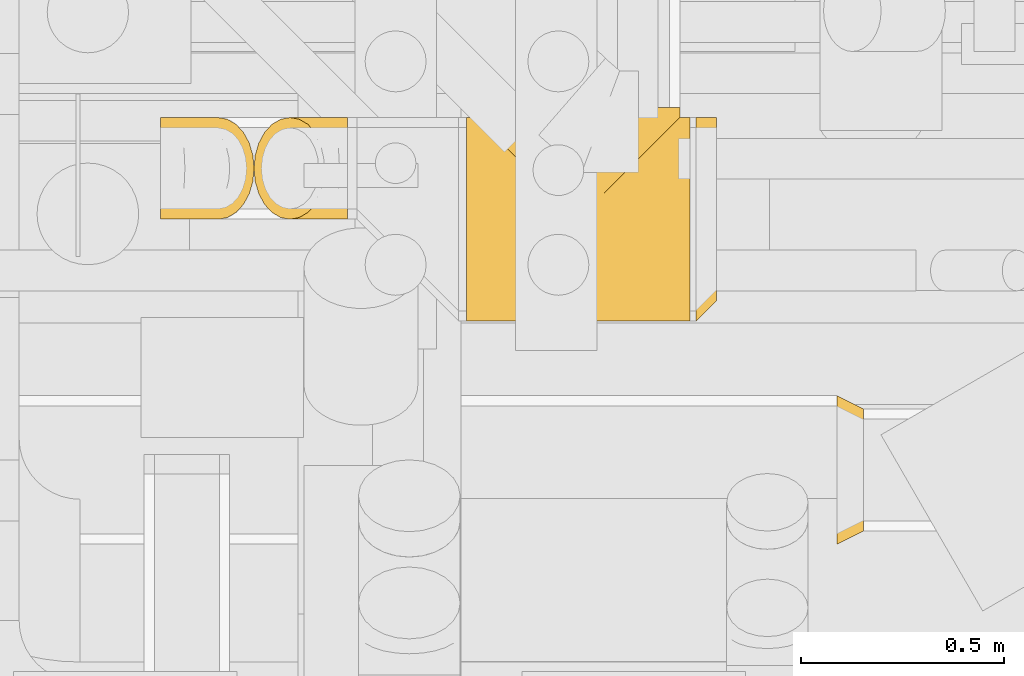
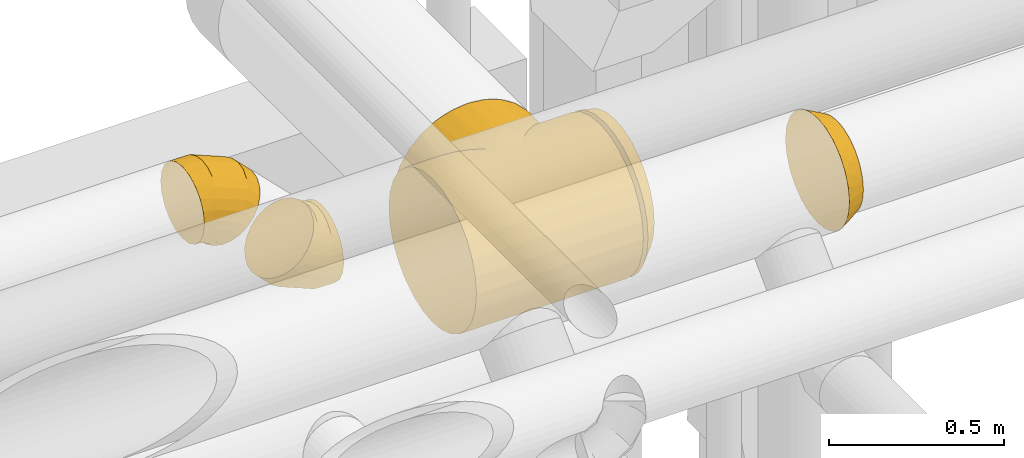
# One storey, part 15 of 337: 5 coverings.
"""IFC2X3 building model written with IfcOpenShell, lengths in millimetres."""

from ifc_helpers import new_model, entity, si_unit, converted_unit, derived_unit, direction, frame, origin, place, context, subcontext, project, spatial, faceted_brep, element, save


model = new_model("IFC2X3")

# Units and contexts
model_context = context("Model", 3, precision=0.01, world=origin(), true_north=direction((6.12303176911189e-17, 1.0)))
body_context = subcontext(model_context, "Body", "Model", "MODEL_VIEW")
ifc_project = project(units=[si_unit("LENGTHUNIT", "METRE", prefix="MILLI"), si_unit("AREAUNIT", "SQUARE_METRE"), si_unit("VOLUMEUNIT", "CUBIC_METRE"), converted_unit("PLANEANGLEUNIT", "DEGREE", entity("IfcRatioMeasure", 0.0174532925199433), si_unit("PLANEANGLEUNIT", "RADIAN"), dimensions=[0, 0, 0, 0, 0, 0, 0]), si_unit("MASSUNIT", "GRAM", prefix="KILO"), derived_unit("MASSDENSITYUNIT", [(si_unit("MASSUNIT", "GRAM", prefix="KILO"), 1), (si_unit("LENGTHUNIT", "METRE"), -3)]), derived_unit("MOMENTOFINERTIAUNIT", [(si_unit("LENGTHUNIT", "METRE"), 4)]), si_unit("TIMEUNIT", "SECOND"), si_unit("FREQUENCYUNIT", "HERTZ"), si_unit("THERMODYNAMICTEMPERATUREUNIT", "DEGREE_CELSIUS"), derived_unit("THERMALTRANSMITTANCEUNIT", [(si_unit("MASSUNIT", "GRAM", prefix="KILO"), 1), (si_unit("THERMODYNAMICTEMPERATUREUNIT", "KELVIN"), -1), (si_unit("TIMEUNIT", "SECOND"), -3)]), derived_unit("VOLUMETRICFLOWRATEUNIT", [(si_unit("LENGTHUNIT", "METRE"), 3), (si_unit("TIMEUNIT", "SECOND"), -1)]), derived_unit("MASSFLOWRATEUNIT", [(si_unit("MASSUNIT", "GRAM", prefix="KILO"), 1), (si_unit("TIMEUNIT", "SECOND"), -1)]), derived_unit("ROTATIONALFREQUENCYUNIT", [(si_unit("TIMEUNIT", "SECOND"), -1)]), si_unit("ELECTRICCURRENTUNIT", "AMPERE"), si_unit("ELECTRICVOLTAGEUNIT", "VOLT"), si_unit("POWERUNIT", "WATT"), si_unit("FORCEUNIT", "NEWTON", prefix="KILO"), si_unit("ILLUMINANCEUNIT", "LUX"), si_unit("LUMINOUSFLUXUNIT", "LUMEN"), si_unit("LUMINOUSINTENSITYUNIT", "CANDELA"), derived_unit("USERDEFINED", [(si_unit("MASSUNIT", "GRAM", prefix="KILO"), -1), (si_unit("LENGTHUNIT", "METRE"), -2), (si_unit("TIMEUNIT", "SECOND"), 3), (si_unit("LUMINOUSFLUXUNIT", "LUMEN"), 1)]), derived_unit("LINEARVELOCITYUNIT", [(si_unit("LENGTHUNIT", "METRE"), 1), (si_unit("TIMEUNIT", "SECOND"), -1)]), si_unit("PRESSUREUNIT", "PASCAL"), derived_unit("USERDEFINED", [(si_unit("LENGTHUNIT", "METRE"), -2), (si_unit("MASSUNIT", "GRAM", prefix="KILO"), 1), (si_unit("TIMEUNIT", "SECOND"), -2)]), derived_unit("LINEARFORCEUNIT", [(si_unit("MASSUNIT", "GRAM", prefix="KILO"), 1), (si_unit("LENGTHUNIT", "METRE"), 1), (si_unit("TIMEUNIT", "SECOND"), -2), (si_unit("LENGTHUNIT", "METRE"), -1)]), derived_unit("PLANARFORCEUNIT", [(si_unit("MASSUNIT", "GRAM", prefix="KILO"), 1), (si_unit("LENGTHUNIT", "METRE"), 1), (si_unit("TIMEUNIT", "SECOND"), -2), (si_unit("LENGTHUNIT", "METRE"), -2)])], contexts=[model_context])

# Site, building, storey
site_placement = place(None, origin())
site = spatial("IfcSite", under=ifc_project, at=site_placement, CompositionType="ELEMENT")
building_placement = place(site_placement, origin())
building = spatial("IfcBuilding", under=site, at=building_placement, CompositionType="ELEMENT")
storey_placement = place(building_placement, origin())
storey = spatial("IfcBuildingStorey", under=building, at=storey_placement, CompositionType="ELEMENT", Elevation=0.0)

# Coverings
covering_1_placement = place(storey_placement, frame((57310.12, 9473.4, 2914.23)))
element("IfcCovering", 1, at=covering_1_placement, inside=storey, PredefinedType="INSULATION", context=body_context, shape_type="Brep", body=[
    faceted_brep([(550.0, 500.03, 237.69), (524.43, 501.03, 239.69), (550.0, 501.6, 251.6), (550.0, 496.89, 209.87), (550.0, 495.33, 195.97), (520.5, 497.1, 204.39), (523.86, 500.46, 227.78), (550.0, 498.46, 223.78), (550.0, 486.08, 169.54), (550.0, 476.84, 143.12), (507.73, 484.33, 160.3), (517.78, 494.38, 193.1), (522.18, 498.78, 216.09), (550.0, 447.05, 95.72), (476.75, 453.34, 103.95), (550.0, 461.95, 119.42), (515.06, 491.65, 181.8), (550.0, 490.7, 182.75), (308.7, 285.3, 3.88), (413.02, 251.6, 1.6), (291.87, 268.47, 2.17), (498.75, 475.35, 140.08), (525.0, 501.6, 251.6), (25.57, 501.03, 239.69), (0.0, 501.6, 251.6), (25.0, 501.6, 251.6), (488.35, 464.95, 121.28), (450.66, 427.25, 73.71), (464.13, 440.72, 88.1), (550.0, 407.47, 56.14), (436.48, 413.08, 60.75), (421.72, 398.31, 49.18), (550.0, 360.07, 26.35), (374.82, 351.42, 22.39), (550.0, 307.23, 7.86), (390.81, 367.41, 30.04), (406.47, 383.06, 38.95), (550.0, 251.6, 1.6), (0.0, 251.6, 1.6), (0.0, 307.23, 7.86), (136.98, 251.6, 1.6), (342.09, 318.69, 10.77), (358.56, 335.16, 15.97), (325.46, 302.05, 6.74), (275.0, 251.6, 1.6), (258.13, 268.47, 2.17), (307.1, 283.7, 499.53), (550.0, 251.6, 501.6), (550.0, 307.23, 495.33), (400.54, 377.14, 467.79), (550.0, 360.07, 476.84), (550.0, 407.47, 447.05), (429.52, 406.11, 448.13), (443.31, 419.91, 436.45), (370.2, 346.8, 482.76), (515.09, 491.69, 317.74), (550.0, 486.08, 333.65), (550.0, 490.7, 320.44), (550.0, 495.33, 307.23), (275.0, 251.6, 501.6), (242.9, 283.7, 499.53), (0.0, 251.6, 501.6), (520.92, 497.51, 296.6), (518.0, 494.6, 307.17), (338.94, 315.53, 493.28), (523.98, 500.57, 262.85), (26.02, 500.57, 262.85), (550.0, 498.46, 279.41), (522.96, 499.55, 274.1), (521.94, 498.53, 285.35), (550.0, 496.89, 293.32), (550.0, 500.03, 265.5), (491.46, 468.05, 376.68), (550.0, 461.95, 383.77), (550.0, 476.84, 360.07), (469.04, 445.64, 409.23), (550.0, 447.05, 407.47), (500.36, 476.96, 357.79), (509.26, 485.86, 338.89), (0.0, 7.86, 195.97), (0.0, 1.6, 251.6), (0.0, 7.86, 307.23), (0.0, 26.35, 360.07), (0.0, 56.14, 407.47), (0.0, 95.72, 447.05), (0.0, 143.12, 476.84), (0.0, 195.97, 495.33), (0.0, 307.23, 495.33), (0.0, 360.07, 476.84), (0.0, 407.47, 447.05), (0.0, 447.05, 407.47), (0.0, 461.95, 383.77), (0.0, 476.84, 360.07), (0.0, 486.08, 333.65), (0.0, 490.7, 320.44), (0.0, 495.33, 307.23), (0.0, 496.89, 293.32), (0.0, 498.46, 279.41), (0.0, 500.03, 265.5), (0.0, 500.03, 237.69), (0.0, 498.46, 223.78), (0.0, 496.89, 209.87), (0.0, 495.33, 195.97), (0.0, 490.7, 182.75), (0.0, 486.08, 169.54), (0.0, 476.84, 143.12), (0.0, 461.95, 119.42), (0.0, 447.05, 95.72), (0.0, 407.47, 56.14), (0.0, 360.07, 26.35), (0.0, 195.97, 7.86), (0.0, 143.12, 26.35), (0.0, 95.72, 56.14), (0.0, 56.14, 95.72), (0.0, 26.35, 143.12), (550.0, 195.97, 495.33), (550.0, 143.12, 476.84), (550.0, 95.72, 447.05), (550.0, 56.14, 407.47), (550.0, 26.35, 360.07), (550.0, 7.86, 307.23), (550.0, 1.6, 251.6), (550.0, 7.86, 195.97), (550.0, 26.35, 143.12), (550.0, 56.14, 95.72), (550.0, 95.72, 56.14), (550.0, 143.12, 26.35), (550.0, 195.97, 7.86), (28.06, 498.53, 285.35), (27.04, 499.55, 274.1), (29.08, 497.51, 296.6), (34.91, 491.69, 317.74), (32.0, 494.6, 307.17), (179.8, 346.8, 482.76), (149.46, 377.14, 467.79), (211.06, 315.53, 493.28), (120.48, 406.11, 448.13), (106.69, 419.91, 436.45), (80.96, 445.64, 409.23), (58.54, 468.05, 376.68), (40.74, 485.86, 338.89), (49.64, 476.96, 357.79), (29.5, 497.1, 204.39), (32.22, 494.38, 193.1), (42.27, 484.33, 160.3), (51.25, 475.35, 140.08), (85.87, 440.72, 88.1), (99.34, 427.25, 73.71), (34.94, 491.65, 181.8), (73.25, 453.34, 103.95), (26.14, 500.46, 227.78), (27.82, 498.78, 216.09), (61.65, 464.95, 121.28), (191.44, 335.16, 15.97), (207.91, 318.69, 10.77), (175.18, 351.42, 22.39), (241.3, 285.3, 3.88), (224.54, 302.05, 6.74), (128.28, 398.31, 49.18), (113.52, 413.08, 60.75), (143.53, 383.06, 38.95), (159.19, 367.41, 30.04), (330.63, 526.6, 495.33), (383.47, 526.6, 476.84), (430.87, 526.6, 447.05), (470.46, 526.6, 407.47), (485.35, 526.6, 383.77), (500.24, 526.6, 360.07), (509.49, 526.6, 333.65), (514.11, 526.6, 320.44), (518.73, 526.6, 307.23), (520.3, 526.6, 293.32), (521.87, 526.6, 279.41), (523.43, 526.6, 265.5), (525.0, 526.6, 251.6), (523.43, 526.6, 237.69), (521.87, 526.6, 223.78), (520.3, 526.6, 209.87), (518.73, 526.6, 195.97), (514.11, 526.6, 182.75), (509.49, 526.6, 169.54), (500.24, 526.6, 143.12), (485.35, 526.6, 119.42), (470.46, 526.6, 95.72), (430.87, 526.6, 56.14), (383.47, 526.6, 26.35), (330.63, 526.6, 7.86), (275.0, 526.6, 1.6), (219.37, 526.6, 7.86), (166.53, 526.6, 26.35), (119.13, 526.6, 56.14), (79.54, 526.6, 95.72), (64.65, 526.6, 119.42), (49.76, 526.6, 143.12), (40.51, 526.6, 169.54), (35.89, 526.6, 182.75), (31.27, 526.6, 195.97), (29.7, 526.6, 209.87), (28.13, 526.6, 223.78), (26.57, 526.6, 237.69), (25.0, 526.6, 251.6), (26.57, 526.6, 265.5), (28.13, 526.6, 279.41), (29.7, 526.6, 293.32), (31.27, 526.6, 307.23), (35.89, 526.6, 320.44), (40.51, 526.6, 333.65), (49.76, 526.6, 360.07), (64.65, 526.6, 383.77), (79.54, 526.6, 407.47), (119.13, 526.6, 447.05), (166.53, 526.6, 476.84), (219.37, 526.6, 495.33), (275.0, 526.6, 501.6), (275.0, 389.62, 1.6)], [[[0, 1, 2]], [[3, 4, 5]], [[6, 0, 7]], [[8, 9, 10]], [[11, 5, 4]], [[7, 3, 12]], [[13, 14, 15]], [[16, 17, 8]], [[18, 19, 20]], [[16, 8, 10]], [[21, 10, 9]], [[17, 11, 4]], [[2, 1, 22]], [[23, 24, 25]], [[26, 15, 14]], [[11, 17, 16]], [[27, 28, 13]], [[14, 13, 28]], [[7, 12, 6]], [[9, 15, 21]], [[21, 15, 26]], [[13, 29, 27]], [[3, 5, 12]], [[30, 29, 31]], [[29, 30, 27]], [[31, 29, 32]], [[33, 32, 34]], [[35, 36, 32]], [[32, 36, 31]], [[37, 19, 34]], [[38, 39, 40]], [[33, 35, 32]], [[41, 42, 34]], [[33, 34, 42]], [[43, 34, 19]], [[44, 20, 19]], [[45, 44, 40]], [[18, 43, 19]], [[41, 34, 43]], [[0, 6, 1]], [[46, 47, 48]], [[49, 50, 51]], [[52, 51, 53]], [[48, 50, 54]], [[51, 52, 49]], [[55, 56, 57, 58]], [[46, 59, 47]], [[59, 60, 61]], [[58, 62, 63, 55]], [[54, 64, 48]], [[49, 54, 50]], [[65, 2, 22]], [[24, 66, 25]], [[46, 48, 64]], [[67, 68, 69]], [[62, 58, 70]], [[68, 67, 71]], [[72, 73, 74]], [[65, 68, 71]], [[62, 70, 69]], [[70, 67, 69]], [[75, 53, 76]], [[75, 73, 72]], [[77, 72, 74, 78]], [[78, 56, 55]], [[78, 74, 56]], [[76, 73, 75]], [[76, 53, 51]], [[2, 65, 71]], [[79, 80, 81, 82, 83, 84, 85, 86, 61, 87, 88, 89, 90, 91, 92, 93, 94, 95, 96, 97, 98, 24, 99, 100, 101, 102, 103, 104, 105, 106, 107, 108, 109, 39, 38, 110, 111, 112, 113, 114]], [[115, 116, 117, 118, 119, 120, 121, 122, 123, 124, 125, 126, 127, 37, 34, 32, 29, 13, 15, 9, 8, 17, 4, 3, 7, 0, 2, 71, 67, 70, 58, 57, 56, 74, 73, 76, 51, 50, 48, 47]], [[121, 120, 81, 80]], [[120, 119, 82, 81]], [[82, 119, 118, 83]], [[118, 117, 84, 83]], [[84, 117, 116, 85]], [[85, 116, 115, 86]], [[59, 61, 86, 115, 47]], [[97, 128, 129]], [[128, 96, 130]], [[95, 131, 132, 130]], [[133, 134, 88]], [[135, 133, 87]], [[96, 128, 97]], [[60, 135, 87]], [[98, 129, 66]], [[61, 60, 87]], [[134, 89, 88]], [[88, 87, 133]], [[89, 136, 137]], [[89, 134, 136]], [[131, 95, 94, 93]], [[137, 138, 90]], [[139, 92, 91]], [[66, 24, 98]], [[131, 93, 140]], [[141, 140, 92, 139]], [[139, 91, 138]], [[138, 91, 90]], [[130, 96, 95]], [[93, 92, 140]], [[129, 98, 97]], [[137, 90, 89]], [[102, 142, 143]], [[144, 145, 105]], [[144, 105, 104]], [[146, 147, 107]], [[148, 104, 103]], [[149, 107, 106]], [[142, 102, 101]], [[146, 107, 149]], [[150, 100, 99]], [[101, 151, 142]], [[152, 106, 145]], [[150, 99, 23]], [[149, 106, 152]], [[150, 151, 100]], [[148, 103, 143]], [[143, 103, 102]], [[106, 105, 145]], [[144, 104, 148]], [[147, 108, 107]], [[100, 151, 101]], [[153, 154, 39]], [[155, 153, 39]], [[156, 40, 157]], [[40, 156, 45]], [[154, 157, 39]], [[108, 158, 109]], [[24, 23, 99]], [[159, 108, 147]], [[108, 159, 158]], [[158, 160, 109]], [[161, 109, 160]], [[161, 155, 109]], [[109, 155, 39]], [[39, 157, 40]], [[127, 110, 38, 40, 44, 19, 37]], [[110, 127, 126, 111]], [[111, 126, 125, 112]], [[113, 124, 123, 114]], [[114, 123, 122, 79]], [[79, 122, 121, 80]], [[112, 125, 124, 113]], [[162, 163, 164, 165, 166, 167, 168, 169, 170, 171, 172, 173, 174, 175, 176, 177, 178, 179, 180, 181, 182, 183, 184, 185, 186, 187, 188, 189, 190, 191, 192, 193, 194, 195, 196, 197, 198, 199, 200, 201, 202, 203, 204, 205, 206, 207, 208, 209, 210, 211, 212, 213]], [[173, 172, 68]], [[171, 69, 172]], [[174, 65, 22]], [[78, 168, 167]], [[62, 171, 170]], [[166, 165, 75]], [[55, 168, 78]], [[63, 62, 170, 55]], [[167, 72, 77, 78]], [[72, 166, 75]], [[53, 75, 165]], [[72, 167, 166]], [[65, 174, 173]], [[165, 164, 53]], [[168, 55, 170, 169]], [[164, 52, 53]], [[49, 52, 164]], [[54, 163, 162]], [[164, 163, 49]], [[46, 162, 213]], [[172, 69, 68]], [[54, 49, 163]], [[173, 68, 65]], [[46, 64, 162]], [[59, 46, 213]], [[54, 162, 64]], [[69, 171, 62]], [[60, 213, 212]], [[134, 211, 210]], [[136, 210, 137]], [[212, 211, 133]], [[210, 136, 134]], [[131, 206, 205, 204]], [[60, 59, 213]], [[204, 130, 132, 131]], [[133, 135, 212]], [[134, 133, 211]], [[66, 200, 25]], [[60, 212, 135]], [[202, 129, 128]], [[130, 204, 203]], [[129, 202, 201]], [[139, 208, 207]], [[66, 129, 201]], [[130, 203, 128]], [[203, 202, 128]], [[138, 137, 209]], [[138, 208, 139]], [[141, 139, 207, 140]], [[140, 206, 131]], [[140, 207, 206]], [[209, 208, 138]], [[209, 137, 210]], [[200, 66, 201]], [[199, 23, 200]], [[197, 196, 142]], [[150, 199, 198]], [[194, 193, 144]], [[143, 142, 196]], [[198, 197, 151]], [[191, 149, 192]], [[148, 195, 194]], [[156, 214, 45]], [[148, 194, 144]], [[145, 144, 193]], [[195, 143, 196]], [[200, 23, 25]], [[152, 192, 149]], [[143, 195, 148]], [[147, 146, 191]], [[149, 191, 146]], [[198, 151, 150]], [[193, 192, 145]], [[145, 192, 152]], [[191, 190, 147]], [[197, 142, 151]], [[159, 190, 158]], [[190, 159, 147]], [[158, 190, 189]], [[155, 189, 188]], [[161, 160, 189]], [[189, 160, 158]], [[187, 214, 188]], [[155, 161, 189]], [[154, 153, 188]], [[155, 188, 153]], [[157, 188, 214]], [[44, 45, 214]], [[156, 157, 214]], [[154, 188, 157]], [[199, 150, 23]], [[214, 186, 43]], [[185, 33, 186]], [[31, 184, 30]], [[31, 36, 185]], [[35, 185, 36]], [[185, 184, 31]], [[35, 33, 185]], [[187, 186, 214]], [[20, 214, 18]], [[33, 42, 186]], [[41, 43, 186]], [[42, 41, 186]], [[214, 43, 18]], [[21, 182, 181]], [[11, 179, 178]], [[1, 6, 175]], [[14, 182, 26]], [[6, 12, 176]], [[10, 180, 16]], [[174, 22, 1]], [[16, 179, 11]], [[16, 180, 179]], [[14, 28, 183]], [[6, 176, 175]], [[30, 184, 27]], [[5, 178, 177]], [[28, 27, 183]], [[177, 12, 5]], [[10, 181, 180]], [[178, 5, 11]], [[26, 182, 21]], [[20, 44, 214]], [[10, 21, 181]], [[183, 182, 14]], [[176, 12, 177]], [[174, 1, 175]], [[27, 184, 183]]]),
])
covering_2_placement = place(storey_placement, frame((56558.69, 9723.4, 3371.44)))
element("IfcCovering", 2, at=covering_2_placement, inside=storey, PredefinedType="INSULATION", context=body_context, shape_type="Brep", body=[
    faceted_brep([(0.0, 165.22, 29.68), (0.0, 126.6, 23.56), (0.0, 87.97, 29.68), (0.0, 53.12, 47.44), (0.0, 25.47, 75.09), (0.0, 7.71, 109.94), (0.0, 1.6, 148.56), (0.0, 7.71, 187.19), (0.0, 25.47, 222.04), (0.0, 53.12, 249.69), (0.0, 87.97, 267.44), (0.0, 126.6, 273.56), (0.0, 165.22, 267.44), (0.0, 200.07, 249.69), (0.0, 227.72, 222.04), (0.0, 245.48, 187.19), (0.0, 251.6, 148.56), (0.0, 245.48, 109.94), (0.0, 227.72, 75.09), (0.0, 200.07, 47.44), (226.8, 158.95, 175.36), (229.81, 126.6, 178.37), (226.8, 94.24, 175.36), (217.97, 64.1, 166.53), (203.92, 38.21, 152.48), (185.62, 18.34, 134.18), (164.3, 5.85, 112.86), (141.42, 1.6, 89.98), (118.54, 5.85, 67.11), (97.23, 18.34, 45.79), (78.92, 38.21, 27.48), (64.87, 64.1, 13.44), (56.04, 94.24, 4.61), (53.03, 126.6, 1.6), (56.04, 158.95, 4.61), (64.87, 189.1, 13.44), (78.92, 214.98, 27.48), (97.23, 234.85, 45.79), (118.54, 247.34, 67.11), (141.42, 251.6, 89.98), (164.3, 247.34, 112.86), (185.62, 234.85, 134.18), (203.92, 214.98, 152.48), (217.97, 189.1, 166.53), (184.1, 126.6, 224.08), (181.69, 94.24, 220.47), (174.61, 64.1, 209.89), (163.36, 38.21, 193.05), (148.69, 18.34, 171.1), (131.62, 5.85, 145.54), (113.29, 1.6, 118.11), (94.96, 5.85, 90.69), (77.89, 18.34, 65.13), (63.22, 38.21, 43.18), (51.97, 64.1, 26.34), (44.9, 94.24, 15.76), (42.48, 126.6, 12.14), (44.9, 158.95, 15.76), (51.97, 189.1, 26.34), (63.22, 214.98, 43.18), (94.96, 247.34, 90.69), (113.29, 251.6, 118.11), (77.89, 234.85, 65.13), (131.62, 247.34, 145.54), (148.69, 234.85, 171.1), (163.36, 214.98, 193.05), (174.61, 189.1, 209.89), (181.69, 158.95, 220.47), (64.65, 126.6, 273.56), (63.8, 94.24, 269.3), (61.32, 64.1, 256.82), (57.36, 38.21, 236.95), (52.21, 18.34, 211.06), (46.22, 5.85, 180.91), (39.78, 1.6, 148.56), (33.35, 5.85, 116.21), (27.35, 18.34, 86.06), (22.2, 38.21, 60.17), (18.25, 64.1, 40.31), (15.77, 94.24, 27.82), (14.92, 126.6, 23.56), (15.77, 158.95, 27.82), (18.25, 189.1, 40.31), (22.2, 214.98, 60.17), (33.35, 247.34, 116.21), (39.78, 251.6, 148.56), (27.35, 234.85, 86.06), (46.22, 247.34, 180.91), (52.21, 234.85, 211.06), (57.36, 214.98, 236.95), (61.32, 189.1, 256.82), (63.8, 158.95, 269.3)], [[[0, 1, 2, 3, 4, 5, 6, 7, 8, 9, 10, 11, 12, 13, 14, 15, 16, 17, 18, 19]], [[20, 21, 22, 23, 24, 25, 26, 27, 28, 29, 30, 31, 32, 33, 34, 35, 36, 37, 38, 39, 40, 41, 42, 43]], [[21, 44, 45, 22]], [[22, 45, 46, 23]], [[23, 46, 47, 24]], [[25, 48, 49, 26]], [[26, 49, 50, 27]], [[24, 47, 48, 25]], [[51, 52, 29, 28]], [[50, 51, 28, 27]], [[53, 30, 29, 52]], [[54, 55, 32, 31]], [[54, 31, 30, 53]], [[56, 33, 32, 55]], [[57, 58, 35, 34]], [[56, 57, 34, 33]], [[36, 35, 58, 59]], [[60, 61, 39, 38]], [[62, 60, 38, 37]], [[59, 62, 37, 36]], [[41, 40, 63, 64]], [[42, 41, 64, 65]], [[39, 61, 63, 40]], [[20, 43, 66, 67]], [[21, 20, 67, 44]], [[42, 65, 66, 43]], [[45, 44, 68, 69]], [[46, 45, 69, 70]], [[70, 71, 47, 46]], [[48, 47, 71, 72]], [[49, 48, 72, 73]], [[50, 49, 73, 74]], [[75, 76, 52, 51]], [[74, 75, 51, 50]], [[53, 52, 76, 77]], [[78, 79, 55, 54]], [[77, 78, 54, 53]], [[56, 55, 79, 80]], [[81, 82, 58, 57]], [[80, 81, 57, 56]], [[59, 58, 82, 83]], [[84, 85, 61, 60]], [[86, 84, 60, 62]], [[83, 86, 62, 59]], [[63, 61, 85, 87]], [[64, 63, 87, 88]], [[65, 64, 88, 89]], [[67, 66, 90, 91]], [[44, 67, 91, 68]], [[89, 90, 66, 65]], [[69, 11, 10]], [[70, 10, 9]], [[11, 69, 68]], [[69, 10, 70]], [[9, 71, 70]], [[72, 8, 7]], [[73, 7, 6]], [[71, 8, 72]], [[72, 7, 73]], [[6, 74, 73]], [[8, 71, 9]], [[75, 6, 5]], [[76, 5, 4]], [[75, 74, 6]], [[76, 75, 5]], [[4, 77, 76]], [[78, 3, 2]], [[79, 2, 1]], [[78, 77, 3]], [[80, 79, 1]], [[78, 2, 79]], [[3, 77, 4]], [[81, 1, 0]], [[82, 0, 19]], [[81, 80, 1]], [[82, 81, 0]], [[19, 83, 82]], [[86, 18, 17]], [[84, 17, 16]], [[86, 83, 18]], [[85, 84, 16]], [[86, 17, 84]], [[18, 83, 19]], [[87, 16, 15]], [[88, 15, 14]], [[16, 87, 85]], [[87, 15, 88]], [[14, 89, 88]], [[12, 11, 91]], [[13, 12, 90]], [[89, 13, 90]], [[91, 90, 12]], [[68, 91, 11]], [[13, 89, 14]]]),
])
covering_3_placement = place(storey_placement, frame((56786.77, 9723.4, 3099.61)))
element("IfcCovering", 3, at=covering_3_placement, inside=storey, PredefinedType="INSULATION", context=body_context, shape_type="Brep", body=[
    faceted_brep([(231.41, 165.22, 245.48), (231.41, 126.6, 251.6), (231.41, 87.97, 245.48), (231.41, 53.12, 227.72), (231.41, 25.47, 200.07), (231.41, 7.71, 165.22), (231.41, 1.6, 126.6), (231.41, 7.71, 87.97), (231.41, 25.47, 53.12), (231.41, 53.12, 25.47), (231.41, 87.97, 7.71), (231.41, 126.6, 1.6), (231.41, 165.22, 7.71), (231.41, 200.07, 25.47), (231.41, 227.72, 53.12), (231.41, 245.48, 87.97), (231.41, 251.6, 126.6), (231.41, 245.48, 165.22), (231.41, 227.72, 200.07), (231.41, 200.07, 227.72), (4.61, 158.95, 99.8), (1.6, 126.6, 96.79), (4.61, 94.24, 99.8), (13.44, 64.1, 108.63), (27.48, 38.21, 122.67), (45.79, 18.34, 140.98), (67.11, 5.85, 162.3), (89.98, 1.6, 185.17), (112.86, 5.85, 208.05), (134.18, 18.34, 229.37), (152.48, 38.21, 247.67), (166.53, 64.1, 261.72), (175.36, 94.24, 270.55), (178.37, 126.6, 273.56), (175.36, 158.95, 270.55), (166.53, 189.1, 261.72), (152.48, 214.98, 247.67), (134.18, 234.85, 229.37), (112.86, 247.34, 208.05), (89.98, 251.6, 185.17), (67.11, 247.34, 162.3), (45.79, 234.85, 140.98), (27.48, 214.98, 122.67), (13.44, 189.1, 108.63), (47.31, 126.6, 51.07), (49.72, 94.24, 54.68), (56.79, 64.1, 65.27), (68.05, 38.21, 82.11), (82.71, 18.34, 104.06), (99.79, 5.85, 129.62), (118.11, 1.6, 157.04), (136.44, 5.85, 184.47), (153.52, 18.34, 210.03), (168.18, 38.21, 231.98), (179.43, 64.1, 248.82), (186.51, 94.24, 259.4), (188.92, 126.6, 263.01), (186.51, 158.95, 259.4), (179.43, 189.1, 248.82), (168.18, 214.98, 231.98), (136.44, 247.34, 184.47), (118.11, 251.6, 157.04), (153.52, 234.85, 210.03), (99.79, 247.34, 129.62), (82.71, 234.85, 104.06), (68.05, 214.98, 82.11), (56.79, 189.1, 65.27), (49.72, 158.95, 54.68), (166.76, 126.6, 1.6), (167.61, 94.24, 5.85), (170.09, 64.1, 18.34), (174.04, 38.21, 38.21), (179.19, 18.34, 64.1), (185.19, 5.85, 94.24), (191.62, 1.6, 126.6), (198.06, 5.85, 158.95), (204.05, 18.34, 189.1), (209.2, 38.21, 214.98), (213.16, 64.1, 234.85), (215.64, 94.24, 247.34), (216.49, 126.6, 251.6), (215.64, 158.95, 247.34), (213.16, 189.1, 234.85), (209.2, 214.98, 214.98), (198.06, 247.34, 158.95), (191.62, 251.6, 126.6), (204.05, 234.85, 189.1), (185.19, 247.34, 94.24), (179.19, 234.85, 64.1), (174.04, 214.98, 38.21), (170.09, 189.1, 18.34), (167.61, 158.95, 5.85)], [[[0, 1, 2, 3, 4, 5, 6, 7, 8, 9, 10, 11, 12, 13, 14, 15, 16, 17, 18, 19]], [[20, 21, 22, 23, 24, 25, 26, 27, 28, 29, 30, 31, 32, 33, 34, 35, 36, 37, 38, 39, 40, 41, 42, 43]], [[21, 44, 45, 22]], [[22, 45, 46, 23]], [[23, 46, 47, 24]], [[25, 48, 49, 26]], [[26, 49, 50, 27]], [[24, 47, 48, 25]], [[51, 52, 29, 28]], [[50, 51, 28, 27]], [[53, 30, 29, 52]], [[54, 55, 32, 31]], [[54, 31, 30, 53]], [[56, 33, 32, 55]], [[57, 58, 35, 34]], [[56, 57, 34, 33]], [[36, 35, 58, 59]], [[60, 61, 39, 38]], [[62, 60, 38, 37]], [[59, 62, 37, 36]], [[41, 40, 63, 64]], [[42, 41, 64, 65]], [[39, 61, 63, 40]], [[20, 43, 66, 67]], [[21, 20, 67, 44]], [[42, 65, 66, 43]], [[45, 44, 68, 69]], [[46, 45, 69, 70]], [[70, 71, 47, 46]], [[48, 47, 71, 72]], [[49, 48, 72, 73]], [[50, 49, 73, 74]], [[75, 76, 52, 51]], [[74, 75, 51, 50]], [[53, 52, 76, 77]], [[78, 79, 55, 54]], [[77, 78, 54, 53]], [[56, 55, 79, 80]], [[81, 82, 58, 57]], [[80, 81, 57, 56]], [[59, 58, 82, 83]], [[84, 85, 61, 60]], [[86, 84, 60, 62]], [[83, 86, 62, 59]], [[63, 61, 85, 87]], [[64, 63, 87, 88]], [[65, 64, 88, 89]], [[67, 66, 90, 91]], [[44, 67, 91, 68]], [[89, 90, 66, 65]], [[69, 11, 10]], [[70, 10, 9]], [[11, 69, 68]], [[69, 10, 70]], [[9, 71, 70]], [[72, 8, 7]], [[73, 7, 6]], [[71, 8, 72]], [[72, 7, 73]], [[6, 74, 73]], [[8, 71, 9]], [[75, 6, 5]], [[76, 5, 4]], [[75, 74, 6]], [[76, 75, 5]], [[4, 77, 76]], [[78, 3, 2]], [[79, 2, 1]], [[78, 77, 3]], [[80, 79, 1]], [[78, 2, 79]], [[3, 77, 4]], [[81, 1, 0]], [[82, 0, 19]], [[81, 80, 1]], [[82, 81, 0]], [[19, 83, 82]], [[86, 18, 17]], [[84, 17, 16]], [[86, 83, 18]], [[85, 84, 16]], [[86, 17, 84]], [[18, 83, 19]], [[87, 16, 15]], [[88, 15, 14]], [[16, 87, 85]], [[87, 15, 88]], [[14, 89, 88]], [[12, 11, 91]], [[13, 12, 90]], [[89, 13, 90]], [[91, 90, 12]], [[68, 91, 11]], [[13, 89, 14]]]),
])
covering_4_placement = place(storey_placement, frame((57875.32, 9473.4, 2914.23)))
element("IfcCovering", 4, at=covering_4_placement, inside=storey, PredefinedType="INSULATION", context=body_context, shape_type="Brep", body=[
    faceted_brep([(50.0, 178.97, 456.53), (50.0, 136.31, 429.72), (50.0, 100.68, 394.1), (50.0, 73.88, 351.43), (50.0, 57.24, 303.88), (50.0, 51.6, 253.81), (50.0, 57.24, 203.74), (50.0, 73.88, 156.19), (50.0, 100.68, 113.52), (50.0, 136.31, 77.9), (50.0, 178.97, 51.09), (50.0, 226.53, 34.45), (50.0, 276.6, 28.81), (50.0, 326.66, 34.45), (50.0, 374.22, 51.09), (50.0, 416.88, 77.9), (50.0, 452.51, 113.52), (50.0, 479.31, 156.19), (50.0, 495.95, 203.74), (50.0, 501.6, 253.81), (50.0, 495.95, 303.88), (50.0, 479.31, 351.43), (50.0, 452.51, 394.1), (50.0, 416.88, 429.72), (50.0, 374.22, 456.53), (50.0, 326.66, 473.17), (50.0, 276.6, 478.81), (50.0, 226.53, 473.17), (0.0, 251.6, 501.6), (0.0, 307.23, 495.33), (0.0, 360.07, 476.84), (0.0, 407.47, 447.05), (0.0, 447.05, 407.47), (0.0, 476.84, 360.07), (0.0, 495.33, 307.23), (0.0, 501.6, 251.6), (0.0, 495.33, 195.97), (0.0, 476.84, 143.12), (0.0, 447.05, 95.72), (0.0, 407.47, 56.14), (0.0, 360.07, 26.35), (0.0, 307.23, 7.86), (0.0, 251.6, 1.6), (0.0, 195.97, 7.86), (0.0, 143.12, 26.35), (0.0, 95.72, 56.14), (0.0, 56.14, 95.72), (0.0, 26.35, 143.12), (0.0, 7.86, 195.97), (0.0, 1.6, 251.6), (0.0, 7.86, 307.23), (0.0, 26.35, 360.07), (0.0, 56.14, 407.47), (0.0, 95.72, 447.05), (0.0, 143.12, 476.84), (0.0, 195.97, 495.33), (21.72, 23.32, 252.56), (25.0, 39.92, 174.26), (25.0, 63.0, 126.34), (21.54, 23.13, 252.55), (25.0, 96.16, 84.76), (25.0, 185.65, 28.53), (21.72, 262.46, 13.42), (25.0, 137.74, 51.61), (19.32, 261.25, 12.11), (25.0, 342.54, 28.53), (25.0, 390.45, 51.61), (25.0, 432.03, 84.76), (25.0, 465.19, 126.34), (25.0, 488.27, 174.26), (19.32, 501.6, 252.45), (19.05, 501.6, 252.44), (25.0, 488.27, 331.14), (25.0, 465.19, 379.06), (25.0, 432.03, 420.64), (25.0, 390.45, 453.8), (25.0, 342.54, 476.87), (19.05, 261.12, 492.91), (21.54, 262.36, 491.78), (25.0, 185.65, 476.87), (25.0, 137.74, 453.8), (25.0, 96.16, 420.64), (25.0, 39.92, 331.14), (25.0, 63.0, 379.06)], [[[0, 1, 2, 3, 4, 5, 6, 7, 8, 9, 10, 11, 12, 13, 14, 15, 16, 17, 18, 19, 20, 21, 22, 23, 24, 25, 26, 27]], [[28, 29, 30, 31, 32, 33, 34, 35, 36, 37, 38, 39, 40, 41, 42, 43, 44, 45, 46, 47, 48, 49, 50, 51, 52, 53, 54, 55]], [[56, 48, 57]], [[7, 58, 8]], [[47, 46, 58]], [[56, 6, 5]], [[48, 56, 59, 49]], [[6, 57, 7]], [[48, 47, 57]], [[58, 57, 47]], [[60, 58, 46]], [[57, 58, 7]], [[57, 6, 56]], [[58, 60, 8]], [[60, 9, 8]], [[61, 43, 62]], [[63, 45, 44]], [[45, 60, 46]], [[61, 44, 43]], [[9, 63, 10]], [[62, 12, 11]], [[43, 42, 64, 62]], [[61, 63, 44]], [[63, 9, 60]], [[61, 10, 63]], [[62, 11, 61]], [[60, 45, 63]], [[10, 61, 11]], [[64, 41, 65]], [[64, 42, 41]], [[13, 12, 62, 64]], [[40, 39, 66]], [[65, 40, 66]], [[66, 67, 15]], [[41, 40, 65]], [[67, 66, 39]], [[14, 66, 15]], [[65, 66, 14]], [[65, 14, 13]], [[64, 65, 13]], [[67, 16, 15]], [[16, 68, 17]], [[68, 38, 37]], [[69, 68, 37]], [[69, 37, 36]], [[70, 19, 18]], [[36, 35, 71, 70]], [[38, 67, 39]], [[68, 16, 67]], [[70, 18, 69]], [[69, 17, 68]], [[17, 69, 18]], [[67, 38, 68]], [[69, 36, 70]], [[71, 34, 72]], [[71, 35, 34]], [[20, 19, 70, 71]], [[33, 32, 73]], [[72, 33, 73]], [[73, 74, 22]], [[34, 33, 72]], [[74, 73, 32]], [[21, 73, 22]], [[72, 73, 21]], [[72, 21, 20]], [[71, 72, 20]], [[74, 23, 22]], [[23, 75, 24]], [[75, 31, 30]], [[76, 75, 30]], [[76, 30, 29]], [[25, 77, 78, 26]], [[29, 28, 77]], [[31, 74, 32]], [[75, 23, 74]], [[77, 25, 76]], [[76, 24, 75]], [[24, 76, 25]], [[74, 31, 75]], [[76, 29, 77]], [[78, 55, 79]], [[78, 27, 26]], [[55, 78, 77, 28]], [[54, 53, 80]], [[0, 80, 1]], [[78, 79, 27]], [[55, 54, 79]], [[81, 80, 53]], [[79, 54, 80]], [[79, 80, 0]], [[79, 0, 27]], [[80, 81, 1]], [[81, 2, 1]], [[82, 50, 59]], [[83, 52, 51]], [[52, 81, 53]], [[82, 51, 50]], [[2, 83, 3]], [[4, 59, 56, 5]], [[50, 49, 59]], [[82, 83, 51]], [[83, 2, 81]], [[82, 3, 83]], [[59, 4, 82]], [[81, 52, 83]], [[3, 82, 4]]]),
])
covering_5_placement = place(storey_placement, frame((58221.4, 8924.55, 3315.94)))
element("IfcCovering", 5, at=covering_5_placement, inside=storey, PredefinedType="INSULATION", context=body_context, shape_type="Brep", body=[
    faceted_brep([(65.0, 184.1, 334.1), (65.0, 145.27, 328.99), (65.0, 109.1, 314.0), (65.0, 78.03, 290.16), (65.0, 54.19, 259.1), (65.0, 39.21, 222.92), (65.0, 34.1, 184.1), (65.0, 39.21, 145.27), (65.0, 54.19, 109.1), (65.0, 78.03, 78.03), (65.0, 109.1, 54.19), (65.0, 145.27, 39.21), (65.0, 184.1, 34.1), (65.0, 222.92, 39.21), (65.0, 259.1, 54.19), (65.0, 290.16, 78.03), (65.0, 314.0, 109.1), (65.0, 328.98, 145.27), (65.0, 334.1, 184.1), (65.0, 328.98, 222.92), (65.0, 314.0, 259.1), (65.0, 290.16, 290.16), (65.0, 259.1, 314.0), (65.0, 222.92, 328.99), (0.0, 231.33, 360.38), (0.0, 275.35, 342.14), (0.0, 313.14, 313.14), (0.0, 342.14, 275.35), (0.0, 360.38, 231.33), (0.0, 366.6, 184.1), (0.0, 360.38, 136.86), (0.0, 342.14, 92.85), (0.0, 313.14, 55.05), (0.0, 275.35, 26.05), (0.0, 231.33, 7.81), (0.0, 184.1, 1.6), (0.0, 136.86, 7.81), (0.0, 92.85, 26.05), (0.0, 55.05, 55.05), (0.0, 26.05, 92.85), (0.0, 7.81, 136.86), (0.0, 1.6, 184.1), (0.0, 7.81, 231.33), (0.0, 26.05, 275.35), (0.0, 55.05, 313.14), (0.0, 92.85, 342.14), (0.0, 136.86, 360.38), (0.0, 184.1, 366.6), (32.5, 30.5, 120.48), (32.5, 52.2, 82.89), (31.05, 20.33, 151.51), (30.81, 17.0, 184.1), (33.91, 151.85, 21.72), (32.5, 82.89, 52.2), (32.5, 120.47, 30.5), (30.81, 184.1, 17.0), (32.5, 247.72, 30.5), (32.5, 285.3, 52.2), (31.05, 216.69, 20.33), (33.91, 346.47, 151.86), (32.5, 315.99, 82.89), (32.5, 337.69, 120.48), (30.81, 351.19, 184.1), (32.5, 337.69, 247.72), (32.5, 315.99, 285.3), (31.05, 347.86, 216.69), (33.9, 216.34, 346.47), (32.5, 285.3, 315.99), (32.5, 247.72, 337.69), (30.8, 184.1, 351.19), (32.5, 120.47, 337.69), (32.5, 82.89, 315.99), (31.05, 151.5, 347.86), (33.9, 21.72, 216.34), (32.5, 52.2, 285.3), (32.5, 30.5, 247.72)], [[[0, 1, 2, 3, 4, 5, 6, 7, 8, 9, 10, 11, 12, 13, 14, 15, 16, 17, 18, 19, 20, 21, 22, 23]], [[24, 25, 26, 27, 28, 29, 30, 31, 32, 33, 34, 35, 36, 37, 38, 39, 40, 41, 42, 43, 44, 45, 46, 47]], [[48, 39, 49]], [[6, 50, 7]], [[40, 39, 48]], [[50, 40, 48]], [[51, 41, 50, 6]], [[48, 49, 8]], [[41, 40, 50]], [[9, 8, 49]], [[48, 8, 7]], [[35, 52, 36]], [[53, 49, 38]], [[37, 53, 38]], [[54, 37, 36]], [[10, 54, 11]], [[35, 55, 12, 52]], [[12, 11, 52]], [[53, 10, 9]], [[54, 53, 37]], [[54, 10, 53]], [[49, 53, 9]], [[52, 11, 54]], [[36, 52, 54]], [[38, 49, 39]], [[7, 50, 48]], [[56, 33, 57]], [[12, 58, 13]], [[34, 33, 56]], [[58, 34, 56]], [[55, 35, 58, 12]], [[56, 57, 14]], [[35, 34, 58]], [[15, 14, 57]], [[56, 14, 13]], [[29, 59, 30]], [[60, 57, 32]], [[31, 60, 32]], [[61, 31, 30]], [[16, 61, 17]], [[29, 62, 18, 59]], [[18, 17, 59]], [[60, 16, 15]], [[61, 60, 31]], [[61, 16, 60]], [[57, 60, 15]], [[59, 17, 61]], [[30, 59, 61]], [[32, 57, 33]], [[13, 58, 56]], [[63, 27, 64]], [[18, 65, 19]], [[28, 27, 63]], [[65, 28, 63]], [[62, 29, 65, 18]], [[63, 64, 20]], [[29, 28, 65]], [[21, 20, 64]], [[63, 20, 19]], [[47, 66, 24]], [[67, 64, 26]], [[25, 67, 26]], [[68, 25, 24]], [[22, 68, 23]], [[47, 69, 0, 66]], [[0, 23, 66]], [[67, 22, 21]], [[68, 67, 25]], [[68, 22, 67]], [[64, 67, 21]], [[66, 23, 68]], [[24, 66, 68]], [[26, 64, 27]], [[19, 65, 63]], [[70, 45, 71]], [[0, 72, 1]], [[46, 45, 70]], [[72, 46, 70]], [[69, 47, 72, 0]], [[70, 71, 2]], [[47, 46, 72]], [[3, 2, 71]], [[70, 2, 1]], [[41, 73, 42]], [[74, 71, 44]], [[43, 74, 44]], [[75, 43, 42]], [[4, 75, 5]], [[41, 51, 6, 73]], [[6, 5, 73]], [[74, 4, 3]], [[75, 74, 43]], [[75, 4, 74]], [[71, 74, 3]], [[73, 5, 75]], [[42, 73, 75]], [[44, 71, 45]], [[1, 72, 70]]]),
])

save(model, "model.ifc")
